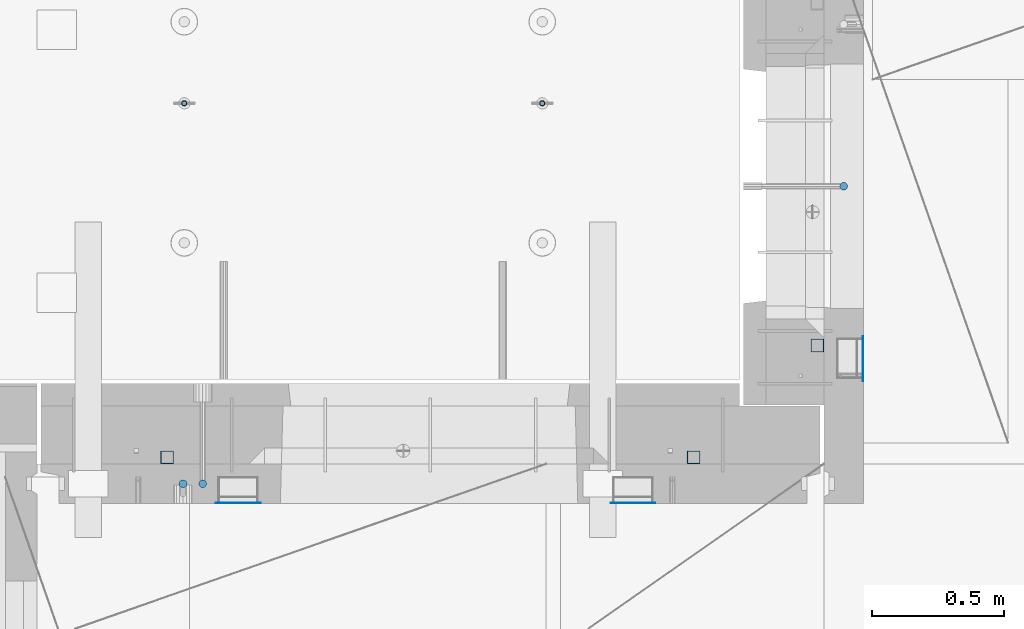
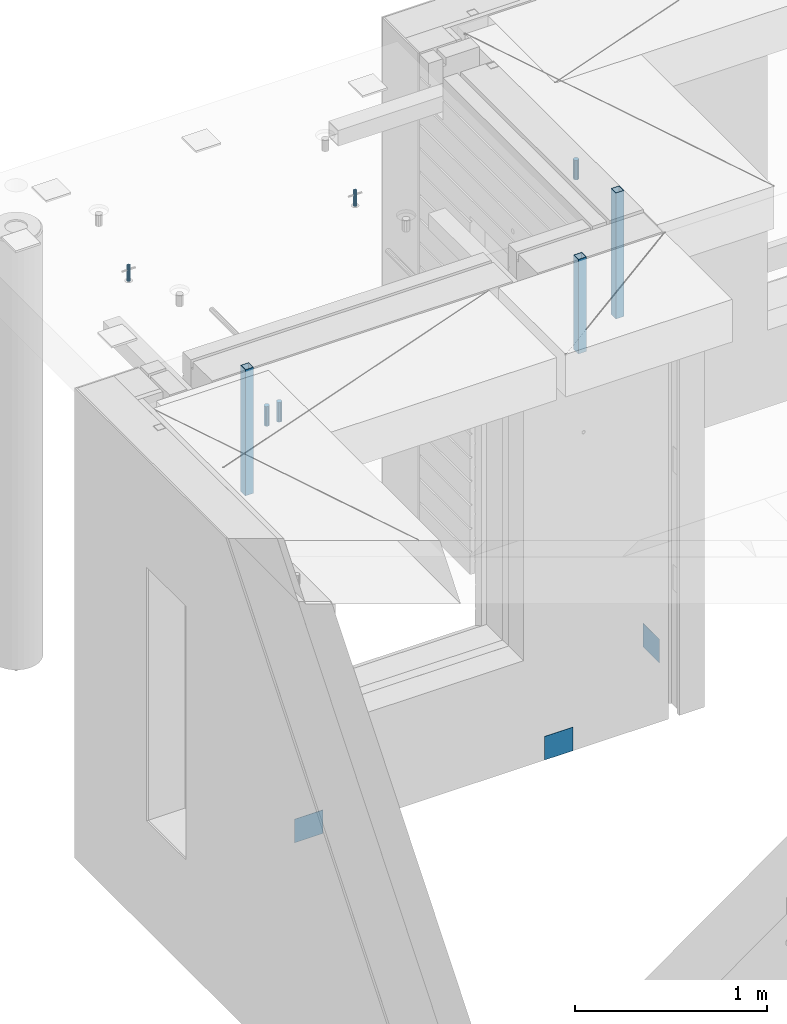
# One storey, part 23 of 309: 11 columns, 11 elements without a shape of their own.
"""IFC2X3 building model written with IfcOpenShell, lengths in millimetres."""

from ifc_helpers import new_model, si_unit, frame, origin_with_axes, place, context, subcontext, project, spatial, faceted_brep, material, type_object, element, aggregate, save


model = new_model("IFC2X3")

# Units and contexts
model_context = context("Model", 3, precision=1e-05, world=origin_with_axes())
body_context = subcontext(model_context, "Body", "Model", "MODEL_VIEW")
ifc_project = project(units=[si_unit("LENGTHUNIT", "METRE", prefix="MILLI"), si_unit("AREAUNIT", "SQUARE_METRE"), si_unit("VOLUMEUNIT", "CUBIC_METRE"), si_unit("MASSUNIT", "GRAM", prefix="KILO"), si_unit("TIMEUNIT", "SECOND"), si_unit("PLANEANGLEUNIT", "RADIAN"), si_unit("SOLIDANGLEUNIT", "STERADIAN"), si_unit("THERMODYNAMICTEMPERATUREUNIT", "DEGREE_CELSIUS"), si_unit("LUMINOUSINTENSITYUNIT", "LUMEN")], contexts=[model_context])

# Site, building, storey
site_placement = place(None, origin_with_axes())
site = spatial("IfcSite", under=ifc_project, at=site_placement, CompositionType="ELEMENT")
building_placement = place(site_placement, origin_with_axes())
building = spatial("IfcBuilding", under=site, at=building_placement, CompositionType="ELEMENT")
storey_placement = place(building_placement, origin_with_axes())
storey = spatial("IfcBuildingStorey", under=building, at=storey_placement, Name="7", CompositionType="ELEMENT", Elevation=0.0)

# Assembly, columns
assembly_1_placement = place(storey_placement, origin_with_axes())
assembly_1 = element("IfcElementAssembly", 1, at=assembly_1_placement, inside=storey, AssemblyPlace="NOTDEFINED", PredefinedType="REINFORCEMENT_UNIT")
ifc_material_1 = material()
column_type_1 = type_object("IfcColumnType", Name="D30", PredefinedType="NOTDEFINED")
column_1_placement = place(assembly_1_placement, frame((8555.00000000836, 20504.9951872276, 102407.5), z_axis=(0.0, 1.0, 0.0), x_axis=(0.0, 0.0, 1.0)))
column_1 = element("IfcColumn", 2, at=column_1_placement, type_object=column_type_1, material=ifc_material_1, ObjectType="D30", context=body_context, shape_type="Brep", body=[
    faceted_brep([(0.0, -15.0, 0.0), (0.0, -12.9903810567666, -7.5), (125.0, -12.9903810567666, -7.5), (125.0, -15.0, 0.0), (0.0, -7.5, -12.9903810567666), (125.0, -7.5, -12.9903810567666), (0.0, 0.0, -15.0), (125.0, 0.0, -15.0), (0.0, 7.5, -12.9903810567666), (125.0, 7.5, -12.9903810567666), (0.0, 12.9903810567666, -7.5), (125.0, 12.9903810567666, -7.5), (0.0, 15.0, 0.0), (125.0, 15.0, 0.0), (0.0, 12.9903810567666, 7.5), (125.0, 12.9903810567666, 7.5), (0.0, 7.5, 12.9903810567666), (125.0, 7.5, 12.9903810567666), (0.0, 0.0, 15.0), (125.0, 0.0, 15.0), (0.0, -7.5, 12.9903810567666), (125.0, -7.5, 12.9903810567666), (0.0, -12.9903810567666, 7.5), (125.0, -12.9903810567666, 7.5)], [[[0, 1, 2, 3]], [[1, 4, 5, 2]], [[4, 6, 7, 5]], [[6, 8, 9, 7]], [[8, 10, 11, 9]], [[10, 12, 13, 11]], [[12, 14, 15, 13]], [[14, 16, 17, 15]], [[16, 18, 19, 17]], [[18, 20, 21, 19]], [[20, 22, 23, 21]], [[22, 0, 3, 23]], [[5, 7, 9, 11, 13, 15, 17, 19, 21, 23, 3, 2]], [[22, 20, 18, 16, 14, 12, 10, 8, 6, 4, 1, 0]]]),
])
column_2_placement = place(assembly_1_placement, frame((8630.00733346229, 20504.9951872205, 102407.5), z_axis=(0.0, -1.0, 0.0), x_axis=(0.0, 0.0, 1.0)))
column_2 = element("IfcColumn", 3, at=column_2_placement, type_object=column_type_1, material=ifc_material_1, ObjectType="D30", context=body_context, shape_type="Brep", body=[
    faceted_brep([(0.0, -15.0, 0.0), (0.0, -12.9903810567666, -7.5), (125.0, -12.9903810567666, -7.5), (125.0, -15.0, 0.0), (0.0, -7.5, -12.9903810567666), (125.0, -7.5, -12.9903810567666), (0.0, 0.0, -15.0), (125.0, 0.0, -15.0), (0.0, 7.5, -12.9903810567666), (125.0, 7.5, -12.9903810567666), (0.0, 12.9903810567666, -7.5), (125.0, 12.9903810567666, -7.5), (0.0, 15.0, 0.0), (125.0, 15.0, 0.0), (0.0, 12.9903810567666, 7.5), (125.0, 12.9903810567666, 7.5), (0.0, 7.5, 12.9903810567666), (125.0, 7.5, 12.9903810567666), (0.0, 0.0, 15.0), (125.0, 0.0, 15.0), (0.0, -7.5, 12.9903810567666), (125.0, -7.5, 12.9903810567666), (0.0, -12.9903810567666, 7.5), (125.0, -12.9903810567666, 7.5)], [[[0, 1, 2, 3]], [[1, 4, 5, 2]], [[4, 6, 7, 5]], [[6, 8, 9, 7]], [[8, 10, 11, 9]], [[10, 12, 13, 11]], [[12, 14, 15, 13]], [[14, 16, 17, 15]], [[16, 18, 19, 17]], [[18, 20, 21, 19]], [[20, 22, 23, 21]], [[22, 0, 3, 23]], [[5, 7, 9, 11, 13, 15, 17, 19, 21, 23, 3, 2]], [[22, 20, 18, 16, 14, 12, 10, 8, 6, 4, 1, 0]]]),
])

# Assemblies, columns
assembly_2_placement = place(storey_placement, origin_with_axes())
assembly_2 = element("IfcElementAssembly", 4, at=assembly_2_placement, inside=storey, AssemblyPlace="NOTDEFINED", PredefinedType="REINFORCEMENT_UNIT")
column_3_placement = place(assembly_2_placement, frame((11064.9999999907, 21634.9982799657, 102407.5), z_axis=(1.0, 0.0, 0.0), x_axis=(0.0, 0.0, 1.0)))
column_3 = element("IfcColumn", 5, at=column_3_placement, type_object=column_type_1, material=ifc_material_1, ObjectType="D30", context=body_context, shape_type="Brep", body=[
    faceted_brep([(0.0, -15.0, 0.0), (0.0, -12.9903810567666, -7.5), (125.0, -12.9903810567666, -7.5), (125.0, -15.0, 0.0), (0.0, -7.5, -12.9903810567666), (125.0, -7.5, -12.9903810567666), (0.0, 0.0, -15.0), (125.0, 0.0, -15.0), (0.0, 7.5, -12.9903810567666), (125.0, 7.5, -12.9903810567666), (0.0, 12.9903810567666, -7.5), (125.0, 12.9903810567666, -7.5), (0.0, 15.0, 0.0), (125.0, 15.0, 0.0), (0.0, 12.9903810567666, 7.5), (125.0, 12.9903810567666, 7.5), (0.0, 7.5, 12.9903810567666), (125.0, 7.5, 12.9903810567666), (0.0, 0.0, 15.0), (125.0, 0.0, 15.0), (0.0, -7.5, 12.9903810567666), (125.0, -7.5, 12.9903810567666), (0.0, -12.9903810567666, 7.5), (125.0, -12.9903810567666, 7.5)], [[[0, 1, 2, 3]], [[1, 4, 5, 2]], [[4, 6, 7, 5]], [[6, 8, 9, 7]], [[8, 10, 11, 9]], [[10, 12, 13, 11]], [[12, 14, 15, 13]], [[14, 16, 17, 15]], [[16, 18, 19, 17]], [[18, 20, 21, 19]], [[20, 22, 23, 21]], [[22, 0, 3, 23]], [[5, 7, 9, 11, 13, 15, 17, 19, 21, 23, 3, 2]], [[22, 20, 18, 16, 14, 12, 10, 8, 6, 4, 1, 0]]]),
])
assembly_3_placement = place(assembly_2_placement, origin_with_axes())
assembly_3 = element("IfcElementAssembly", 6, at=assembly_3_placement, Name="Steel Assembly", AssemblyPlace="NOTDEFINED", PredefinedType="NOTDEFINED")
ifc_material_2 = material(Name="Undefined")
column_type_2 = type_object("IfcColumnType", PredefinedType="NOTDEFINED")
column_4_placement = place(assembly_3_placement, frame((11139.0000000031, 20979.9951872276, 99754.9999999969), z_axis=(1.0, 0.0, 0.0), x_axis=(0.0, 0.0, 1.0)))
column_4 = element("IfcColumn", 7, at=column_4_placement, type_object=column_type_2, material=ifc_material_2, Name="SPK2", context=body_context, shape_type="Brep", body=[
    faceted_brep([(0.0, 85.0, -1.0), (0.0, 85.0, 1.0), (150.0, 85.0, 1.0), (150.0, 85.0, -1.0), (0.0, -85.0, 1.0), (150.0, -85.0, 1.0), (0.0, -85.0, -1.0), (150.0, -85.0, -1.0)], [[[0, 1, 2, 3]], [[1, 4, 5, 2]], [[4, 6, 7, 5]], [[6, 0, 3, 7]], [[5, 7, 3, 2]], [[6, 4, 1, 0]]]),
])
aggregate(assembly_3, [column_4])

# Assembly, column
assembly_4_placement = place(assembly_1_placement, origin_with_axes())
assembly_4 = element("IfcElementAssembly", 8, at=assembly_4_placement, Name="Steel Assembly", AssemblyPlace="NOTDEFINED", PredefinedType="NOTDEFINED")
column_5_placement = place(assembly_4_placement, frame((10265.0, 20430.9951872214, 99755.0), z_axis=(0.0, -1.0, 0.0), x_axis=(0.0, 0.0, 1.0)))
column_5 = element("IfcColumn", 9, at=column_5_placement, type_object=column_type_2, material=ifc_material_2, Name="SPK2", context=body_context, shape_type="Brep", body=[
    faceted_brep([(0.0, 85.0, -1.0), (0.0, 85.0, 1.0), (150.0, 85.0, 1.0), (150.0, 85.0, -1.0), (0.0, -85.0, 1.0), (150.0, -85.0, 1.0), (0.0, -85.0, -1.0), (150.0, -85.0, -1.0)], [[[0, 1, 2, 3]], [[1, 4, 5, 2]], [[4, 6, 7, 5]], [[6, 0, 3, 7]], [[5, 7, 3, 2]], [[6, 4, 1, 0]]]),
])
aggregate(assembly_4, [column_5])

assembly_5_placement = place(assembly_1_placement, origin_with_axes())
assembly_5 = element("IfcElementAssembly", 10, at=assembly_5_placement, Name="Steel Assembly", AssemblyPlace="NOTDEFINED", PredefinedType="NOTDEFINED")
column_6_placement = place(assembly_5_placement, frame((8765.0, 20430.9951872214, 99755.0), z_axis=(0.0, -1.0, 0.0), x_axis=(0.0, 0.0, 1.0)))
column_6 = element("IfcColumn", 11, at=column_6_placement, type_object=column_type_2, material=ifc_material_2, Name="SPK2", context=body_context, shape_type="Brep", body=[
    faceted_brep([(0.0, 85.0, -1.0), (0.0, 85.0, 1.0), (150.0, 85.0, 1.0), (150.0, 85.0, -1.0), (0.0, -85.0, 1.0), (150.0, -85.0, 1.0), (0.0, -85.0, -1.0), (150.0, -85.0, -1.0)], [[[0, 1, 2, 3]], [[1, 4, 5, 2]], [[4, 6, 7, 5]], [[6, 0, 3, 7]], [[5, 7, 3, 2]], [[6, 4, 1, 0]]]),
])
aggregate(assembly_5, [column_6])

# Assembly
assembly_6_placement = place(assembly_2_placement, origin_with_axes())
assembly_6 = element("IfcElementAssembly", 12, at=assembly_6_placement, Name="Steel Assembly", AssemblyPlace="NOTDEFINED", PredefinedType="RIGID_FRAME")

aggregate(assembly_2, [column_3, assembly_3, assembly_6])

# Column
ifc_material_3 = material(Name="STEEL/S355J2")
column_type_3 = type_object("IfcColumnType", Name="50X50X3", PredefinedType="NOTDEFINED")
column_7_placement = place(assembly_6_placement, frame((10965.0, 21030.0, 101940.0), z_axis=(1.0, 0.0, 0.0), x_axis=(0.0, 0.0, 1.0)))
column_7 = element("IfcColumn", 13, at=column_7_placement, type_object=column_type_3, material=ifc_material_3, ObjectType="50X50X3", context=body_context, shape_type="Brep", body=[
    faceted_brep([(0.0, 22.0, -22.0), (0.0, -22.0, -22.0), (800.0, -22.0, -22.0), (800.0, 22.0, -22.0), (0.0, -22.0, 22.0), (800.0, -22.0, 22.0), (0.0, 22.0, 22.0), (800.0, 22.0, 22.0), (0.0, 25.0, -25.0), (0.0, 25.0, 25.0), (800.0, 25.0, 25.0), (800.0, 25.0, -25.0), (0.0, -25.0, 25.0), (800.0, -25.0, 25.0), (0.0, -25.0, -25.0), (800.0, -25.0, -25.0)], [[[0, 1, 2, 3]], [[1, 4, 5, 2]], [[4, 6, 7, 5]], [[6, 0, 3, 7]], [[8, 9, 10, 11]], [[9, 12, 13, 10]], [[12, 14, 15, 13]], [[14, 8, 11, 15]], [[13, 15, 11, 10], [5, 7, 3, 2]], [[14, 12, 9, 8], [6, 4, 1, 0]]]),
])

aggregate(assembly_6, [column_7])

# Assembly, column
assembly_7_placement = place(assembly_1_placement, origin_with_axes())
assembly_7 = element("IfcElementAssembly", 14, at=assembly_7_placement, Name="Steel Assembly", AssemblyPlace="NOTDEFINED", PredefinedType="RIGID_FRAME")
column_8_placement = place(assembly_7_placement, frame((8495.0, 20605.0, 101940.0), z_axis=(1.0, 0.0, 0.0), x_axis=(0.0, 0.0, 1.0)))
column_8 = element("IfcColumn", 15, at=column_8_placement, type_object=column_type_3, material=ifc_material_3, ObjectType="50X50X3", context=body_context, shape_type="Brep", body=[
    faceted_brep([(0.0, 22.0, -22.0), (0.0, -22.0, -22.0), (800.0, -22.0, -22.0), (800.0, 22.0, -22.0), (0.0, -22.0, 22.0), (800.0, -22.0, 22.0), (0.0, 22.0, 22.0), (800.0, 22.0, 22.0), (0.0, 25.0, -25.0), (0.0, 25.0, 25.0), (800.0, 25.0, 25.0), (800.0, 25.0, -25.0), (0.0, -25.0, 25.0), (800.0, -25.0, 25.0), (0.0, -25.0, -25.0), (800.0, -25.0, -25.0)], [[[0, 1, 2, 3]], [[1, 4, 5, 2]], [[4, 6, 7, 5]], [[6, 0, 3, 7]], [[8, 9, 10, 11]], [[9, 12, 13, 10]], [[12, 14, 15, 13]], [[14, 8, 11, 15]], [[13, 15, 11, 10], [5, 7, 3, 2]], [[14, 12, 9, 8], [6, 4, 1, 0]]]),
])
aggregate(assembly_7, [column_8])

# Assembly
assembly_8_placement = place(assembly_1_placement, origin_with_axes())
assembly_8 = element("IfcElementAssembly", 16, at=assembly_8_placement, Name="Steel Assembly", AssemblyPlace="NOTDEFINED", PredefinedType="RIGID_FRAME")

aggregate(assembly_1, [column_1, column_2, assembly_4, assembly_5, assembly_7, assembly_8])

# Column
column_9_placement = place(assembly_8_placement, frame((10495.0, 20605.0, 102140.0), z_axis=(1.0, 0.0, 0.0), x_axis=(0.0, 0.0, 1.0)))
column_9 = element("IfcColumn", 17, at=column_9_placement, type_object=column_type_3, material=ifc_material_3, ObjectType="50X50X3", context=body_context, shape_type="Brep", body=[
    faceted_brep([(0.0, 22.0, -22.0), (0.0, -22.0, -22.0), (600.0, -22.0, -22.0), (600.0, 22.0, -22.0), (0.0, -22.0, 22.0), (600.0, -22.0, 22.0), (0.0, 22.0, 22.0), (600.0, 22.0, 22.0), (0.0, 25.0, -25.0), (0.0, 25.0, 25.0), (600.0, 25.0, 25.0), (600.0, 25.0, -25.0), (0.0, -25.0, 25.0), (600.0, -25.0, 25.0), (0.0, -25.0, -25.0), (600.0, -25.0, -25.0)], [[[0, 1, 2, 3]], [[1, 4, 5, 2]], [[4, 6, 7, 5]], [[6, 0, 3, 7]], [[8, 9, 10, 11]], [[9, 12, 13, 10]], [[12, 14, 15, 13]], [[14, 8, 11, 15]], [[13, 15, 11, 10], [5, 7, 3, 2]], [[14, 12, 9, 8], [6, 4, 1, 0]]]),
])

aggregate(assembly_8, [column_9])

# Assemblies, columns
assembly_9_placement = place(storey_placement, origin_with_axes())
assembly_9 = element("IfcElementAssembly", 18, at=assembly_9_placement, inside=storey, AssemblyPlace="NOTDEFINED", PredefinedType="REINFORCEMENT_UNIT")
assembly_10_placement = place(assembly_9_placement, origin_with_axes())
assembly_10 = element("IfcElementAssembly", 19, at=assembly_10_placement, Name="Steel Assembly", AssemblyPlace="NOTDEFINED", PredefinedType="RIGID_FRAME")
ifc_material_4 = material(Name="STEEL/1.4301")
column_type_4 = type_object("IfcColumnType", PredefinedType="NOTDEFINED")
column_10_placement = place(assembly_10_placement, frame((8559.9965866494, 21950.0012615308, 102444.999998325), z_axis=(-1.60829999983552e-05, -0.999999999870669, 0.0), x_axis=(0.0, 0.0, 1.0)))
column_10 = element("IfcColumn", 20, at=column_10_placement, type_object=column_type_4, material=ifc_material_4, context=body_context, shape_type="Brep", body=[
    faceted_brep([(0.0, -8.0, 0.0), (0.0, -6.92820323027263, 4.0), (100.000000000029, -6.92820323027263, 4.0), (100.000000000029, -7.99999999999636, 0.0), (0.0, -4.0, 6.92820323027627), (100.000000000029, -4.0, 6.92820323027536), (0.0, 0.0, 8.0), (100.000000000029, 3.63797880709171e-12, 8.0), (0.0, 4.0, 6.92820323027627), (100.000000000029, 4.0, 6.92820323027536), (0.0, 6.92820323027263, 4.0), (100.000000000029, 6.92820323027627, 3.99999999999909), (0.0, 8.0, 0.0), (100.000000000029, 8.0, 0.0), (0.0, 6.92820323027263, -4.0), (100.000000000029, 6.92820323027627, -4.00000000000091), (0.0, 4.0, -6.92820323027627), (100.000000000029, 4.00000000000364, -6.92820323027536), (0.0, 0.0, -8.0), (100.000000000029, 3.63797880709171e-12, -8.00000000000091), (0.0, -4.0, -6.92820323027627), (100.000000000029, -3.99999999999636, -6.92820323027627), (0.0, -6.92820323027263, -4.0), (100.000000000029, -6.92820323027263, -4.0), (0.0, -10.4999999999927, -1.45519152283669e-11), (0.0, -9.09326673972828, -5.25000000001455), (100.000000000262, -9.09326673972828, -5.25000000001455), (100.000000000262, -10.4999999999927, -1.45519152283669e-11), (0.0, -5.24999999998545, -9.09326673974283), (100.000000000262, -5.24999999998545, -9.09326673974283), (0.0, 7.27595761418343e-12, -10.5), (100.000000000262, 7.27595761418343e-12, -10.5), (0.0, 5.25000000001455, -9.09326673975738), (100.000000000262, 5.25000000001455, -9.09326673975738), (0.0, 9.09326673975011, -5.25000000001455), (100.000000000262, 9.09326673975011, -5.25000000001455), (0.0, 10.5000000000073, -1.45519152283669e-11), (100.000000000262, 10.5000000000073, -1.45519152283669e-11), (0.0, 9.09326673975011, 5.25), (100.000000000262, 9.09326673975011, 5.25), (0.0, 5.25000000000728, 9.09326673972828), (100.000000000262, 5.25000000000728, 9.09326673972828), (0.0, 1.45519152283669e-11, 10.4999999999854), (100.000000000262, 1.45519152283669e-11, 10.4999999999854), (0.0, -5.24999999999272, 9.09326673972828), (100.000000000262, -5.24999999999272, 9.09326673972828), (0.0, -9.09326673972828, 5.24999999998545), (100.000000000262, -9.09326673972828, 5.24999999998545)], [[[0, 1, 2, 3]], [[1, 4, 5, 2]], [[4, 6, 7, 5]], [[6, 8, 9, 7]], [[8, 10, 11, 9]], [[10, 12, 13, 11]], [[12, 14, 15, 13]], [[14, 16, 17, 15]], [[16, 18, 19, 17]], [[18, 20, 21, 19]], [[20, 22, 23, 21]], [[22, 0, 3, 23]], [[24, 25, 26, 27]], [[25, 28, 29, 26]], [[28, 30, 31, 29]], [[30, 32, 33, 31]], [[32, 34, 35, 33]], [[34, 36, 37, 35]], [[36, 38, 39, 37]], [[38, 40, 41, 39]], [[40, 42, 43, 41]], [[42, 44, 45, 43]], [[44, 46, 47, 45]], [[46, 24, 27, 47]], [[29, 31, 33, 35, 37, 39, 41, 43, 45, 47, 27, 26], [5, 7, 9, 11, 13, 15, 17, 19, 21, 23, 3, 2]], [[46, 44, 42, 40, 38, 36, 34, 32, 30, 28, 25, 24], [22, 20, 18, 16, 14, 12, 10, 8, 6, 4, 1, 0]]]),
])
aggregate(assembly_10, [column_10])
assembly_11_placement = place(assembly_9_placement, origin_with_axes())
assembly_11 = element("IfcElementAssembly", 21, at=assembly_11_placement, Name="Steel Assembly", AssemblyPlace="NOTDEFINED", PredefinedType="RIGID_FRAME")
aggregate(assembly_9, [assembly_10, assembly_11])
column_11_placement = place(assembly_11_placement, frame((9919.99658651215, 21949.9841915483, 102444.999998325), z_axis=(-1.60829999983552e-05, -0.999999999870669, 0.0), x_axis=(0.0, 0.0, 1.0)))
column_11 = element("IfcColumn", 22, at=column_11_placement, type_object=column_type_4, material=ifc_material_4, context=body_context, shape_type="Brep", body=[
    faceted_brep([(0.0, -8.0, 0.0), (0.0, -6.92820323027263, 4.0), (100.000000000029, -6.92820323027263, 4.0), (100.000000000029, -7.99999999999636, 0.0), (0.0, -4.0, 6.92820323027627), (100.000000000029, -4.0, 6.92820323027536), (0.0, 0.0, 8.0), (100.000000000029, 3.63797880709171e-12, 8.0), (0.0, 4.0, 6.92820323027627), (100.000000000029, 4.0, 6.92820323027536), (0.0, 6.92820323027263, 4.0), (100.000000000029, 6.92820323027627, 3.99999999999909), (0.0, 8.0, 0.0), (100.000000000029, 8.0, 0.0), (0.0, 6.92820323027263, -4.0), (100.000000000029, 6.92820323027627, -4.00000000000091), (0.0, 4.0, -6.92820323027627), (100.000000000029, 4.00000000000364, -6.92820323027536), (0.0, 0.0, -8.0), (100.000000000029, 3.63797880709171e-12, -8.00000000000091), (0.0, -4.0, -6.92820323027627), (100.000000000029, -3.99999999999636, -6.92820323027627), (0.0, -6.92820323027263, -4.0), (100.000000000029, -6.92820323027263, -4.0), (0.0, -10.4999999999927, -1.45519152283669e-11), (0.0, -9.09326673972828, -5.25000000001455), (100.000000000262, -9.09326673972828, -5.25000000001455), (100.000000000262, -10.4999999999927, -1.45519152283669e-11), (0.0, -5.24999999998545, -9.09326673974283), (100.000000000262, -5.24999999998545, -9.09326673974283), (0.0, 7.27595761418343e-12, -10.5), (100.000000000262, 7.27595761418343e-12, -10.5), (0.0, 5.25000000001455, -9.09326673975738), (100.000000000262, 5.25000000001455, -9.09326673975738), (0.0, 9.09326673975011, -5.25000000001455), (100.000000000262, 9.09326673975011, -5.25000000001455), (0.0, 10.5000000000073, -1.45519152283669e-11), (100.000000000262, 10.5000000000073, -1.45519152283669e-11), (0.0, 9.09326673975011, 5.25), (100.000000000262, 9.09326673975011, 5.25), (0.0, 5.25000000000728, 9.09326673972828), (100.000000000262, 5.25000000000728, 9.09326673972828), (0.0, 1.45519152283669e-11, 10.4999999999854), (100.000000000262, 1.45519152283669e-11, 10.4999999999854), (0.0, -5.24999999999272, 9.09326673972828), (100.000000000262, -5.24999999999272, 9.09326673972828), (0.0, -9.09326673972828, 5.24999999998545), (100.000000000262, -9.09326673972828, 5.24999999998545)], [[[0, 1, 2, 3]], [[1, 4, 5, 2]], [[4, 6, 7, 5]], [[6, 8, 9, 7]], [[8, 10, 11, 9]], [[10, 12, 13, 11]], [[12, 14, 15, 13]], [[14, 16, 17, 15]], [[16, 18, 19, 17]], [[18, 20, 21, 19]], [[20, 22, 23, 21]], [[22, 0, 3, 23]], [[24, 25, 26, 27]], [[25, 28, 29, 26]], [[28, 30, 31, 29]], [[30, 32, 33, 31]], [[32, 34, 35, 33]], [[34, 36, 37, 35]], [[36, 38, 39, 37]], [[38, 40, 41, 39]], [[40, 42, 43, 41]], [[42, 44, 45, 43]], [[44, 46, 47, 45]], [[46, 24, 27, 47]], [[29, 31, 33, 35, 37, 39, 41, 43, 45, 47, 27, 26], [5, 7, 9, 11, 13, 15, 17, 19, 21, 23, 3, 2]], [[46, 44, 42, 40, 38, 36, 34, 32, 30, 28, 25, 24], [22, 20, 18, 16, 14, 12, 10, 8, 6, 4, 1, 0]]]),
])
aggregate(assembly_11, [column_11])

save(model, "model.ifc")
